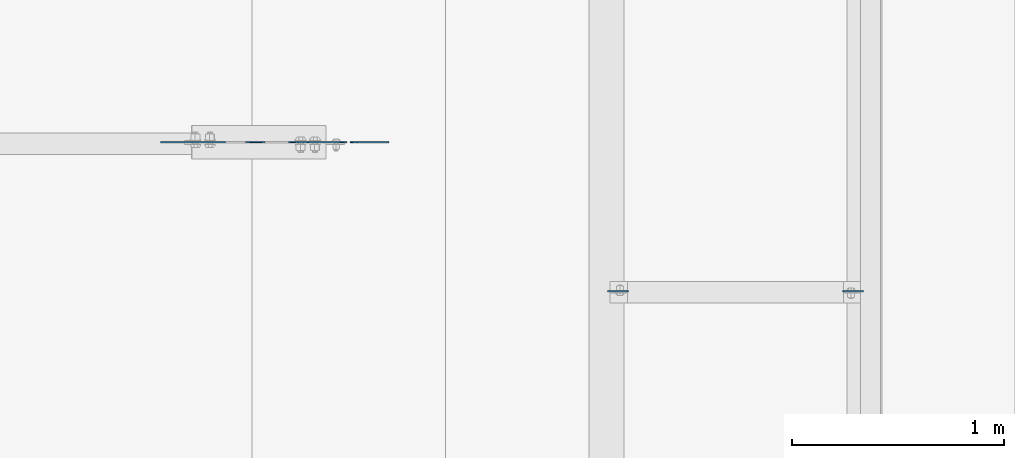
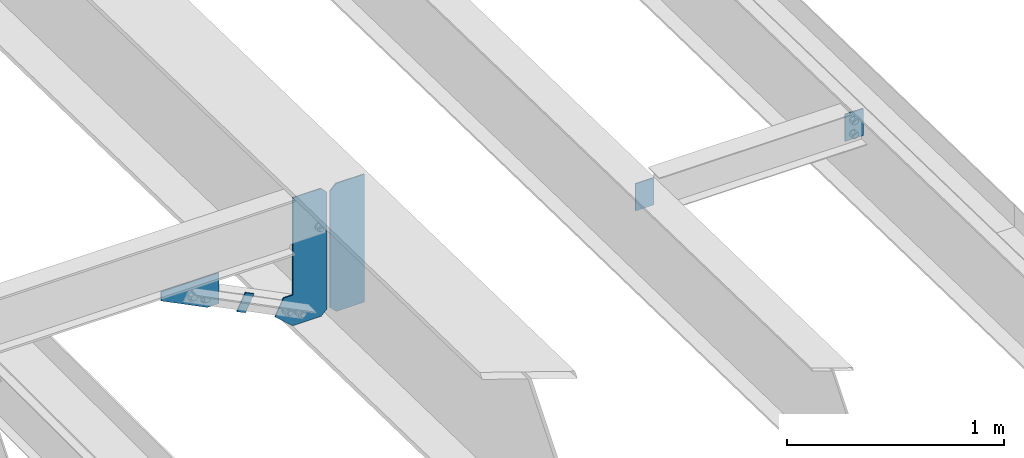
# One storey, part 1579 of 1763: 6 plates, 5 elements without a shape of their own.
"""IFC2X3 building model written with IfcOpenShell, lengths in millimetres."""

from ifc_helpers import new_model, si_unit, frame, origin_with_axes, place, context, subcontext, project, spatial, faceted_brep, material, type_object, element, aggregate, save


model = new_model("IFC2X3")

# Units and contexts
model_context = context("Model", 3, precision=1e-05, world=origin_with_axes())
body_context = subcontext(model_context, "Body", "Model", "MODEL_VIEW")
ifc_project = project(units=[si_unit("LENGTHUNIT", "METRE", prefix="MILLI"), si_unit("AREAUNIT", "SQUARE_METRE"), si_unit("VOLUMEUNIT", "CUBIC_METRE"), si_unit("MASSUNIT", "GRAM", prefix="KILO"), si_unit("TIMEUNIT", "SECOND"), si_unit("PLANEANGLEUNIT", "RADIAN"), si_unit("SOLIDANGLEUNIT", "STERADIAN"), si_unit("THERMODYNAMICTEMPERATUREUNIT", "DEGREE_CELSIUS"), si_unit("LUMINOUSINTENSITYUNIT", "LUMEN")], contexts=[model_context])

# Site, building, storey
site_placement = place(None, origin_with_axes())
site = spatial("IfcSite", under=ifc_project, at=site_placement, CompositionType="ELEMENT")
building_placement = place(site_placement, origin_with_axes())
building = spatial("IfcBuilding", under=site, at=building_placement, Name="Undefined", CompositionType="ELEMENT")
storey_placement = place(building_placement, origin_with_axes())
storey = spatial("IfcBuildingStorey", under=building, at=storey_placement, Name="Undefined", CompositionType="ELEMENT", Elevation=0.0)

# Assembly, plate
assembly_1_placement = place(storey_placement, origin_with_axes())
assembly_1 = element("IfcElementAssembly", 1, at=assembly_1_placement, inside=storey, Name="BEAM", AssemblyPlace="NOTDEFINED", PredefinedType="RIGID_FRAME")
ifc_material = material(Name="STEEL/A36")
plate_type_1 = type_object("IfcPlateType", PredefinedType="NOTDEFINED")
plate_1_placement = place(assembly_1_placement, frame((-24423.7585815478, 21863.0500000164, 10966.1082387367), z_axis=(-0.894427191199916, 0.0, 0.447213595099958), x_axis=(-0.447213595099945, 0.0, -0.894427191199922)))
plate_1 = element("IfcPlate", 2, at=plate_1_placement, type_object=plate_type_1, material=ifc_material, Name="PLATE", context=body_context, shape_type="Brep", body=[
    faceted_brep([(1.81898940354586e-12, -3.17500000000291, 0.0), (0.0, -3.17500000000291, 50.7999992370605), (0.0, 3.17500000000291, 50.7999992370605), (-1.81898940354586e-12, 3.17499999997381, 0.0), (101.599998474121, -3.17500000000291, 50.7999992370605), (101.599998474121, 3.17500000000291, 50.7999992370605), (101.599990844785, -3.17499999999927, -1.81898940354586e-11), (101.599990844785, 3.17499999999927, -1.81898940354586e-11)], [[[0, 1, 2, 3]], [[1, 4, 5, 2]], [[4, 6, 7, 5]], [[6, 0, 3, 7]], [[5, 7, 3, 2]], [[6, 4, 1, 0]]]),
])
aggregate(assembly_1, [plate_1])

assembly_2_placement = place(storey_placement, origin_with_axes())
assembly_2 = element("IfcElementAssembly", 3, at=assembly_2_placement, inside=storey, Name="BEAM", AssemblyPlace="NOTDEFINED", PredefinedType="RIGID_FRAME")
plate_type_2 = type_object("IfcPlateType", PredefinedType="NOTDEFINED")
plate_2_placement = place(assembly_2_placement, frame((-21594.2031443556, 21158.6766663175, 11443.9788444611), z_axis=(-1.0, 0.0, 0.0), x_axis=(0.0, 0.0, -1.0)))
plate_2 = element("IfcPlate", 4, at=plate_2_placement, type_object=plate_type_2, material=ifc_material, Name="PLATE", context=body_context, shape_type="Brep", body=[
    faceted_brep([(1.81898940354586e-12, -3.17500000000291, 0.0), (0.0, -3.17499999999927, 96.8375015258789), (0.0, 3.17499999999927, 96.8375015258789), (-1.81898940354586e-12, 3.17499999997381, 0.0), (152.399993896484, -3.17499999999927, 96.8375015258789), (152.399993896484, 3.17499999999927, 96.8375015258789), (152.399993896484, -3.17500000000291, 0.0), (152.399993896484, 3.17500000000291, 0.0)], [[[0, 1, 2, 3]], [[1, 4, 5, 2]], [[4, 6, 7, 5]], [[6, 0, 3, 7]], [[5, 7, 3, 2]], [[6, 4, 1, 0]]]),
])
aggregate(assembly_2, [plate_2])

assembly_3_placement = place(storey_placement, origin_with_axes())
assembly_3 = element("IfcElementAssembly", 5, at=assembly_3_placement, inside=storey, Name="BEAM", AssemblyPlace="NOTDEFINED", PredefinedType="RIGID_FRAME")
plate_3_placement = place(assembly_3_placement, frame((-22803.8859080275, 21158.6766663175, 11443.9788444611), z_axis=(1.0, 0.0, 0.0), x_axis=(0.0, 0.0, -1.0)))
plate_3 = element("IfcPlate", 6, at=plate_3_placement, type_object=plate_type_2, material=ifc_material, Name="PLATE", context=body_context, shape_type="Brep", body=[
    faceted_brep([(1.81898940354586e-12, -3.17500000000291, 0.0), (0.0, -3.17499999999927, 96.8375015258789), (0.0, 3.17499999999927, 96.8375015258789), (-1.81898940354586e-12, 3.17499999997381, 0.0), (152.399993896484, -3.17499999999927, 96.8375015258789), (152.399993896484, 3.17499999999927, 96.8375015258789), (152.399993896484, -3.17500000000291, 0.0), (152.399993896484, 3.17500000000291, 0.0)], [[[0, 1, 2, 3]], [[1, 4, 5, 2]], [[4, 6, 7, 5]], [[6, 0, 3, 7]], [[5, 7, 3, 2]], [[6, 4, 1, 0]]]),
])
aggregate(assembly_3, [plate_3])

# Assembly, plates
assembly_4_placement = place(storey_placement, origin_with_axes())
assembly_4 = element("IfcElementAssembly", 7, at=assembly_4_placement, inside=storey, Name="BEAM", AssemblyPlace="NOTDEFINED", PredefinedType="RIGID_FRAME")
plate_type_3 = type_object("IfcPlateType", PredefinedType="NOTDEFINED")
plate_4_placement = place(assembly_4_placement, frame((-24019.5997736984, 21863.0500000297, 10714.9651079372), z_axis=(0.0, 0.0, 1.0), x_axis=(1.0, 0.0, 0.0)))
plate_4 = element("IfcPlate", 8, at=plate_4_placement, type_object=plate_type_3, material=ifc_material, Name="PLATE", context=body_context, shape_type="Brep", body=[
    faceted_brep([(0.0, -3.17500000000291, 31.75), (0.0, -3.17499999999927, 686.812194824219), (0.0, 3.17499999999927, 686.812194824219), (0.0, 3.17500000000291, 31.75), (31.75, -3.17499999999927, 718.562194824219), (31.75, 3.17499999999927, 718.562194824219), (182.5625, -3.17499999999927, 718.562194824219), (182.5625, 3.17499999999927, 718.562194824219), (182.5625, -3.17500000000291, 0.0), (182.5625, 3.17500000000291, 0.0), (31.7499999999036, -3.17499999997381, 9.42916855706244e-11), (31.7499999998854, 3.17500000000291, 9.42916855706244e-11)], [[[0, 1, 2, 3]], [[1, 4, 5, 2]], [[4, 6, 7, 5]], [[6, 8, 9, 7]], [[8, 10, 11, 9]], [[10, 0, 3, 11]], [[5, 7, 9, 11, 3, 2]], [[10, 8, 6, 4, 1, 0]]]),
])
plate_type_4 = type_object("IfcPlateType", PredefinedType="NOTDEFINED")
plate_5_placement = place(assembly_4_placement, frame((-24036.0747736984, 21863.0499999804, 10714.9651079372), z_axis=(0.0, 0.0, 1.0), x_axis=(-1.0, 0.0, 0.0)))
plate_5 = element("IfcPlate", 9, at=plate_5_placement, type_object=plate_type_4, material=ifc_material, Name="PLATE", context=body_context, shape_type="Brep", body=[
    faceted_brep([(0.0, -3.17500000000291, 31.75), (0.0, -3.17499999999927, 686.812255859375), (0.0, 3.17499999999927, 686.812255859375), (0.0, 3.17500000000291, 31.75), (31.75, -3.17499999999927, 718.562255859375), (31.75, 3.17499999999927, 718.562255859375), (182.261993408203, -3.17499999999927, 718.562255859375), (182.261993408203, 3.17499999999927, 718.562255859375), (182.261993408203, -3.17499999999927, 172.454345703125), (182.261993408203, 3.17499999999927, 172.454345703125), (230.306228637695, -3.17499999999927, 172.454345703125), (230.306228637695, 3.17499999999927, 172.454345703125), (275.743133544922, -3.17499999999927, 81.5805358886719), (275.743133544922, 3.17499999999927, 81.5805358886719), (182.261993408203, -3.17499999999927, 0.0), (182.261993408203, 3.17499999999927, 0.0), (31.7499999999036, -3.17499999997381, 9.42916855706244e-11), (31.7499999998854, 3.17500000000291, 9.42916855706244e-11)], [[[0, 1, 2, 3]], [[1, 4, 5, 2]], [[4, 6, 7, 5]], [[6, 8, 9, 7]], [[8, 10, 11, 9]], [[10, 12, 13, 11]], [[12, 14, 15, 13]], [[14, 16, 17, 15]], [[16, 0, 3, 17]], [[5, 7, 9, 11, 13, 15, 17, 3, 2]], [[16, 14, 12, 10, 8, 6, 4, 1, 0]]]),
])
aggregate(assembly_4, [plate_4, plate_5])

# Assembly, plate
assembly_5_placement = place(storey_placement, origin_with_axes())
assembly_5 = element("IfcElementAssembly", 10, at=assembly_5_placement, inside=storey, Name="BEAM", AssemblyPlace="NOTDEFINED", PredefinedType="RIGID_FRAME")
plate_type_5 = type_object("IfcPlateType", PredefinedType="NOTDEFINED")
plate_6_placement = place(assembly_5_placement, frame((-24610.7958721203, 21863.0500000299, 11149.8698631154), z_axis=(-1.0, 0.0, 0.0), x_axis=(0.0, 0.0, -1.0)))
plate_6 = element("IfcPlate", 11, at=plate_6_placement, type_object=plate_type_5, material=ifc_material, Name="PLATE", context=body_context, shape_type="Brep", body=[
    faceted_brep([(1.81898940354586e-12, -3.17500000000291, 0.0), (0.0, -3.17499999999927, 306.070465087891), (0.0, 3.17499999999927, 306.070465087891), (-1.81898940354586e-12, 3.17499999997381, 0.0), (50.7999992370605, -3.17499999999927, 306.070465087891), (50.7999992370605, 3.17499999999927, 306.070465087891), (172.922760009766, -3.17499999999927, 61.8249359130859), (172.922760009766, 3.17499999999927, 61.8249359130859), (172.922760009766, -3.17499999999927, 0.0), (172.922760009766, 3.17499999999927, 0.0)], [[[0, 1, 2, 3]], [[1, 4, 5, 2]], [[4, 6, 7, 5]], [[6, 8, 9, 7]], [[8, 0, 3, 9]], [[5, 7, 9, 3, 2]], [[8, 6, 4, 1, 0]]]),
])
aggregate(assembly_5, [plate_6])

save(model, "model.ifc")
